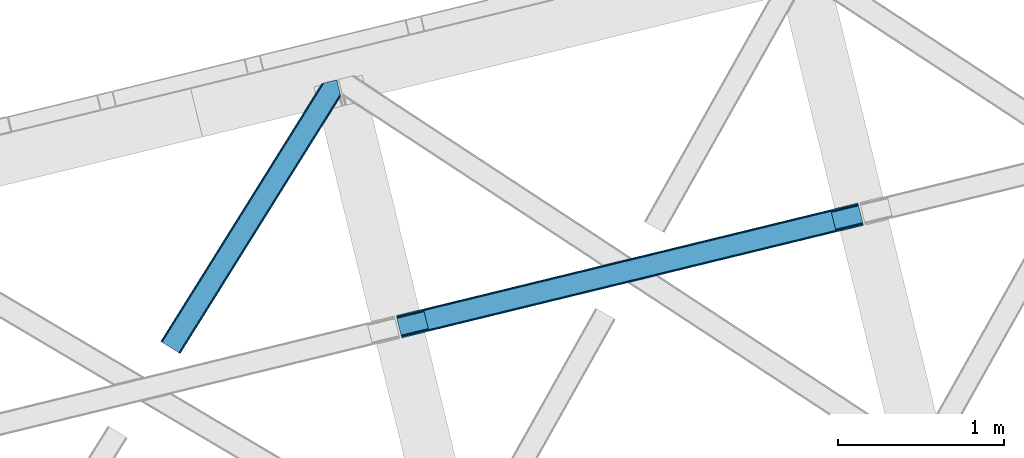
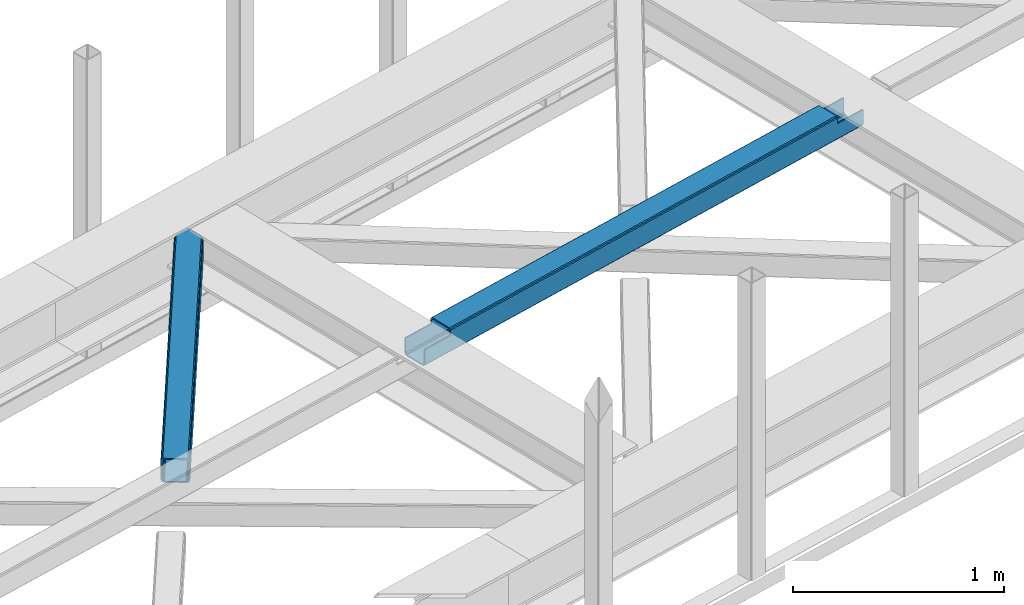
# One storey, part 53 of 66: 1 beam, 1 member.
"""IFC4 building model written with IfcOpenShell, lengths in millimetres."""

from ifc_helpers import new_model, entity, si_unit, converted_unit, derived_unit, direction, frame, origin, place, context, subcontext, project, spatial, triangles, polygons, material, type_object, element, save


model = new_model("IFC4")

# Units and contexts
model_context = context("Model", 3, precision=0.01, world=origin(), true_north=direction((6.12303176911189e-17, 1.0)))
plan_context = context("Plan", 3, precision=0.01, world=origin(), true_north=direction((6.12303176911189e-17, 1.0)))
body_context = subcontext(model_context, "Body", "Model", "MODEL_VIEW")
ifc_project = project(units=[si_unit("LENGTHUNIT", "METRE", prefix="MILLI"), si_unit("AREAUNIT", "SQUARE_METRE"), si_unit("VOLUMEUNIT", "CUBIC_METRE"), converted_unit("PLANEANGLEUNIT", "DEGREE", entity("IfcRatioMeasure", 0.0174532925199433), si_unit("PLANEANGLEUNIT", "RADIAN"), dimensions=[0, 0, 0, 0, 0, 0, 0]), si_unit("MASSUNIT", "GRAM", prefix="KILO"), derived_unit("MASSDENSITYUNIT", [(si_unit("MASSUNIT", "GRAM", prefix="KILO"), 1), (si_unit("LENGTHUNIT", "METRE"), -3)]), derived_unit("MOMENTOFINERTIAUNIT", [(si_unit("LENGTHUNIT", "METRE"), 4)]), si_unit("TIMEUNIT", "SECOND"), si_unit("FREQUENCYUNIT", "HERTZ"), si_unit("THERMODYNAMICTEMPERATUREUNIT", "DEGREE_CELSIUS"), derived_unit("THERMALTRANSMITTANCEUNIT", [(si_unit("MASSUNIT", "GRAM", prefix="KILO"), 1), (si_unit("THERMODYNAMICTEMPERATUREUNIT", "KELVIN"), -1), (si_unit("TIMEUNIT", "SECOND"), -3)]), derived_unit("VOLUMETRICFLOWRATEUNIT", [(si_unit("LENGTHUNIT", "METRE"), 3), (si_unit("TIMEUNIT", "SECOND"), -1)]), derived_unit("MASSFLOWRATEUNIT", [(si_unit("MASSUNIT", "GRAM", prefix="KILO"), 1), (si_unit("TIMEUNIT", "SECOND"), -1)]), derived_unit("ROTATIONALFREQUENCYUNIT", [(si_unit("TIMEUNIT", "SECOND"), -1)]), si_unit("ELECTRICCURRENTUNIT", "AMPERE"), si_unit("ELECTRICVOLTAGEUNIT", "VOLT"), si_unit("POWERUNIT", "WATT"), si_unit("FORCEUNIT", "NEWTON", prefix="KILO"), si_unit("ILLUMINANCEUNIT", "LUX"), si_unit("LUMINOUSFLUXUNIT", "LUMEN"), si_unit("LUMINOUSINTENSITYUNIT", "CANDELA"), derived_unit("USERDEFINED", [(si_unit("MASSUNIT", "GRAM", prefix="KILO"), -1), (si_unit("LENGTHUNIT", "METRE"), -2), (si_unit("TIMEUNIT", "SECOND"), 3), (si_unit("LUMINOUSFLUXUNIT", "LUMEN"), 1)]), derived_unit("LINEARVELOCITYUNIT", [(si_unit("LENGTHUNIT", "METRE"), 1), (si_unit("TIMEUNIT", "SECOND"), -1)]), si_unit("PRESSUREUNIT", "PASCAL"), derived_unit("USERDEFINED", [(si_unit("LENGTHUNIT", "METRE"), -2), (si_unit("MASSUNIT", "GRAM", prefix="KILO"), 1), (si_unit("TIMEUNIT", "SECOND"), -2)]), derived_unit("LINEARFORCEUNIT", [(si_unit("MASSUNIT", "GRAM", prefix="KILO"), 1), (si_unit("LENGTHUNIT", "METRE"), 1), (si_unit("TIMEUNIT", "SECOND"), -2), (si_unit("LENGTHUNIT", "METRE"), -1)]), derived_unit("PLANARFORCEUNIT", [(si_unit("MASSUNIT", "GRAM", prefix="KILO"), 1), (si_unit("LENGTHUNIT", "METRE"), 1), (si_unit("TIMEUNIT", "SECOND"), -2), (si_unit("LENGTHUNIT", "METRE"), -2)])], contexts=[model_context, plan_context])

# Site, building, storey
site_placement = place(None, origin())
site = spatial("IfcSite", under=ifc_project, at=site_placement, CompositionType="ELEMENT")
building_placement = place(site_placement, origin())
building = spatial("IfcBuilding", under=site, at=building_placement, CompositionType="ELEMENT")
storey_placement = place(building_placement, frame((0.0, 0.0, 19800.0)))
storey = spatial("IfcBuildingStorey", under=building, at=storey_placement, Name="06", CompositionType="ELEMENT", Elevation=19800.0)

# Beam
ifc_material = material(Name="Metal painted (White)")
beam_type = type_object("IfcBeamType", PredefinedType="BEAM")
beam_placement = place(storey_placement, frame((-11387.67, 16364.08, 3967.02)))
element("IfcBeam", 1, at=beam_placement, inside=storey, type_object=beam_type, material=ifc_material, ObjectType="Steel Beam", PredefinedType="BEAM", context=body_context, shape_type="Tessellation", body=[
    polygons([(31.1823923917571, 8.09507685196108, 17.8030399336114), (31.4978703677273, 6.80086440699434, 24.4999999999988), (2817.90917311746, 686.018099103278, 24.4999999999988), (2817.59369514149, 687.312311548247, 17.8030399336114), (30.2839871259056, 11.7806820741864, 12.1256313292298), (2816.69528987564, 690.997916770472, 12.1256313292298), (28.9394286278213, 17.2965800886753, 8.33210818105214), (2815.35073137756, 696.513814784959, 8.33210818105214), (27.3534137403861, 23.8030254244661, 7.00000000000274), (2813.76471649012, 703.020260120752, 7.00000000000274), (4.21622439083043, 118.720708051134, 8.33210818105214), (5.80223927826556, 112.214262715343, 7.00000000000274), (2792.213542028, 791.431497411626, 7.00000000000274), (2790.62752714057, 797.937942747419, 8.33210818105214), (2.87166589274824, 124.236606065618, 12.1256313292342), (2789.28296864248, 803.453840761904, 12.1256313292342), (1.9732606268946, 127.922211287848, 17.8030399336114), (2788.38456337663, 807.139445984131, 17.8030399336114), (1.65778265094818, 129.216423732819, 24.4999999999988), (2788.06908540067, 808.433658429104, 24.4999999999988), (33.1556530186734, 6.49720277579036e-12, 17.5000000000004), (33.1556530186734, 6.49720277579036e-12, 99.499999999999), (31.4978703677403, 6.80086440699434, 99.499999999999), (1.65778265095251, 129.216423732821, 99.499999999999), (2.38230768445646e-11, 136.017288139815, 99.499999999999), (2.59888111031614e-11, 136.017288139815, 17.5000000000004), (0.315477975985408, 134.723075694844, 10.803039933613), (1.21388324183688, 131.037470472619, 5.12563132923143), (2.55844173992124, 125.52157245813, 1.33210818105373), (4.14445662735637, 119.015127122339, 0.0), (29.011196391343, 17.0021610174826, 0.0), (30.5972112787781, 10.4957156816896, 1.33210818105373), (31.9417697768603, 4.97981766720068, 5.12563132923576), (32.8401750427139, 1.29421244497757, 10.803039933613), (2786.41130274975, 815.234522836097, 17.5000000000004), (2786.41130274974, 815.234522836097, 99.499999999999), (2788.06908540068, 808.433658429104, 99.499999999999), (2817.90917311746, 686.01809910328, 99.499999999999), (2819.56695576839, 679.217234696288, 99.499999999999), (2819.5669557684, 679.217234696288, 17.5000000000004), (2819.25147779244, 680.511447141259, 10.803039933613), (2818.35307252658, 684.197052363484, 5.12563132923576), (2817.0085140285, 689.712950377973, 1.33210818105373), (2815.42249914106, 696.219395713764, 0.0), (2790.55575937708, 798.23236181862, 0.0), (2788.96974448964, 804.738807154413, 1.33210818105373), (2787.62518599156, 810.254705168902, 5.12563132923143), (2786.72678072571, 813.940310391125, 10.803039933613), (2653.72536552979, 645.996559503588, 115.5000123926), (2653.78173361466, 646.010298722204, 100.117303289864), (2654.68842734968, 646.231315480896, 99.499999999999), (194.718606580794, 46.5876811586757, 99.5063429816656), (195.631369831915, 46.810141494503, 100.117301735448), (195.690168193622, 46.824474122359, 115.5), (2656.34621000061, 639.430451073908, 99.499999999999), (2655.43964990836, 639.209466900397, 100.117303484932), (2655.38006714068, 639.194943868054, 122.500007895425), (197.345360928049, 40.0229783796023, 122.500002534479), (197.338587096739, 40.0213271441479, 100.500009163303), (196.748205195722, 39.8773799905087, 99.5697919021647), (2624.84834918759, 768.646841677419, 99.5063429816656), (2623.93924032811, 768.4252715147, 100.117299778624), (2623.88287224324, 768.411532296082, 115.50000888136), (165.850080476841, 169.240033448183, 115.5), (165.84046220334, 169.237688832046, 100.50000941238), (165.250325295035, 169.093836777333, 99.5761204674868), (2622.81875057266, 775.357142845586, 99.5697919021647), (163.220745767765, 175.804071762184, 99.499999999999), (164.133244938514, 176.026503182399, 100.117301984524), (164.18943998763, 176.04020120897, 122.500002796667), (2622.22174126673, 775.211580304167, 122.500003994045), (2622.23184455557, 775.214043718734, 100.500018741102), (2622.53385542111, 773.916547681999, 129.196959150505), (2623.4271909467, 770.229706340309, 134.874360354937), (2624.76848195077, 764.7130116355, 138.667878733795), (2626.35352903677, 758.206330327425, 139.999985502214), (2651.2242780837, 656.194341778115, 139.999991354279), (2652.81177220129, 649.688257112712, 138.667885332354), (2654.16003176172, 644.173261502483, 134.874367586349), (2655.06379646893, 640.488963035532, 129.196966804773), (2653.41217589809, 647.2913298996, 122.196975799125), (2652.50841119088, 650.975628366557, 127.874376580702), (2651.16015163044, 656.490623976784, 131.667894326702), (2649.57265751286, 662.996708642187, 133.000000348631), (2628.01800833885, 751.407098718257, 132.999995276841), (2626.43296125285, 757.913780026333, 131.667888508414), (2625.09167024878, 763.43047473114, 127.874370129564), (2624.19833472319, 767.117316072832, 122.196968925133), (164.878528418698, 169.003207355194, 99.499999999999), (193.131726453727, 57.3201898040399, 131.667891818946), (191.545711566292, 63.8266351398329, 133.0), (194.476284951809, 51.804291789551, 127.874368670764), (195.374690217663, 48.1186865673279, 122.196960066391), (169.994537104169, 152.237872430707, 133.0), (166.165558452801, 167.945821003215, 122.196960066391), (167.063963718652, 164.260215780991, 127.874368670764), (168.408522216736, 158.744317766502, 131.667891818946), (197.031411944073, 41.3175635421181, 129.196961104604), (196.136488323068, 45.0040174739024, 134.874366301861), (194.794244157317, 50.5204796458773, 138.667887185257), (193.209023953586, 57.0271186992037, 139.999994588639), (168.341882306943, 159.039986838394, 139.999994981919), (166.755021471191, 165.546225960038, 138.667887628704), (165.408105180735, 171.061549222932, 134.874366787843), (164.506189230969, 174.746298656828, 129.196961619)], [[[1, 2, 3, 4]], [[5, 1, 4, 6]], [[7, 5, 6, 8]], [[9, 7, 8, 10]], [[11, 12, 13, 14]], [[15, 11, 14, 16]], [[17, 15, 16, 18]], [[19, 17, 18, 20]], [[12, 9, 10, 13]], [[21, 22, 23, 2, 1, 5, 7, 9, 12, 11, 15, 17, 19, 24, 25, 26, 27, 28, 29, 30, 31, 32, 33, 34]], [[35, 36, 37, 20, 18, 16, 14, 13, 10, 8, 6, 4, 3, 38, 39, 40, 41, 42, 43, 44, 45, 46, 47, 48]], [[49, 50, 51, 38, 3, 2, 23, 52, 53, 54]], [[55, 39, 38, 51]], [[39, 55, 56, 57, 58, 59, 60, 22, 21, 40]], [[32, 31, 44, 43]], [[33, 32, 43, 42]], [[34, 33, 42, 41]], [[21, 34, 41, 40]], [[31, 30, 45, 44]], [[27, 26, 35, 48]], [[28, 27, 48, 47]], [[29, 28, 47, 46]], [[30, 29, 46, 45]], [[20, 37, 61, 62, 63, 64, 65, 66, 24, 19]], [[67, 36, 35, 26, 25, 68, 69, 70, 71, 72]], [[36, 67, 61, 37]], [[72, 71, 73, 74, 75, 76, 77, 78, 79, 80, 57, 56, 50, 49, 81, 82, 83, 84, 85, 86, 87, 88, 63, 62]], [[60, 52, 23, 22]], [[25, 24, 89, 68]], [[90, 91, 84, 83]], [[92, 90, 83, 82]], [[93, 92, 82, 81]], [[54, 93, 81, 49]], [[94, 85, 84, 91]], [[95, 64, 63, 88]], [[96, 95, 88, 87]], [[97, 96, 87, 86]], [[94, 97, 86, 85]], [[65, 64, 95, 96, 97, 94, 91, 90, 92, 93, 54, 53, 59, 58, 98, 99, 100, 101, 102, 103, 104, 105, 70, 69]], [[98, 58, 57, 80]], [[99, 98, 80, 79]], [[100, 99, 79, 78]], [[101, 100, 78, 77]], [[77, 76, 102, 101]], [[103, 102, 76, 75]], [[104, 103, 75, 74]], [[105, 104, 74, 73]], [[70, 105, 73, 71]]], closed=False),
])

# Member
member_type = type_object("IfcMemberType", PredefinedType="BRACE")
member_placement = place(storey_placement, frame((-12809.64, 16269.34, 3823.0)))
element("IfcMember", 2, at=member_placement, inside=storey, type_object=member_type, ObjectType="Steel Horizontal Brace", PredefinedType="BRACE", context=body_context, shape_type="Tessellation", body=[
    triangles([(933.019793701173, 1535.69114685059, 0.0), (967.779299926759, 1393.09054870606, 0.0), (14.8479309082031, 64.8692962646492, 0.0), (103.918075561523, 9.26687622070313, 0.0), (928.802609252929, 1552.99009094238, 5.49966430664063), (928.943298339844, 1552.41570739746, 5.208984375), (930.802487182616, 1544.78594055176, 1.33247680664135), (971.996484375, 1375.79160461426, 5.49966430664063), (971.856958007813, 1376.36598815918, 5.208984375), (969.996606445313, 1383.99575500488, 1.33247680664135), (972.211587524414, 1375.53696899414, 5.8531311035149), (972.422039794921, 1375.28233337402, 6.20659790039281), (928.915393066407, 1553.56912536621, 5.74383544921875), (972.724346923827, 1375.53696899414, 6.35310058593677), (929.030502319336, 1554.17606506348, 5.9996337890625), (973.025491333008, 1375.79160461426, 6.49960327148438), (929.145611572265, 1554.78300476074, 6.25543212890625), (929.253744506836, 1555.36087646485, 6.49960327148438), (4.3520599365238, 71.4223846435543, 5.12526855468968), (1.13365173339844, 73.4315643310547, 10.8039916992202), (973.359191894531, 1630.84231567383, 10.8039916992202), (976.915951538085, 1631.70854187012, 6.49960327148438), (9.16804504394531, 68.4155914306648, 1.33247680664135), (971.506979370117, 1630.3900177002, 17.5012573242202), (0.0, 74.1361724853523, 17.5012573242202), (1081.10028991699, 1548.91592102051, 6.49960327148438), (1056.20762329101, 1651.03643188476, 6.49960327148438), (971.506979370117, 1630.3900177002, 122.499499511719), (0.0, 74.1361724853523, 122.499499511719), (973.359191894531, 1630.84231567383, 129.196765136719), (1.13365173339844, 73.4315643310547, 129.196765136719), (978.636776733398, 1632.12828369141, 134.87548828125), (4.3520599365238, 71.4223846435543, 134.87548828125), (986.530480957032, 1634.05258483887, 138.668280029298), (9.16804504394531, 68.4155914306648, 138.668280029298), (995.83921508789, 1636.32105102539, 140.00075683594), (14.8479309082031, 64.8692962646492, 140.00075683594), (118.762518310547, 0.0, 17.5012573242202), (117.632354736328, 0.705770874023074, 10.8039916992202), (1085.14190368652, 1551.24949951172, 10.9783996582046), (1087.41618347168, 1552.56337280274, 13.4991760253906), (109.597961425781, 5.7205810546875, 1.33247680664135), (114.413946533203, 2.71378784179615, 5.12526855468968), (1087.56966247559, 1551.93434143066, 17.5012573242202), (1081.77583007812, 1575.70149536133, 140.00075683594), (1063.00837097168, 1652.69447021484, 140.00075683594), (103.918075561523, 9.26687622070313, 140.00075683594), (1083.99313659668, 1566.60553894043, 138.668280029298), (109.597961425781, 5.7205810546875, 138.668280029298), (1085.8720916748, 1558.8955444336, 134.87548828125), (114.413946533203, 2.71378784179615, 134.87548828125), (1087.12782897949, 1553.7435333252, 129.196765136719), (117.632354736328, 0.705770874023074, 129.196765136719), (1087.56966247559, 1551.93434143066, 122.499499511719), (118.762518310547, 0.0, 122.499499511719), (1082.53973693848, 1566.77297058106, 12.1248413085959), (1083.96406860352, 1566.72297363281, 13.4991760253906), (1077.85048828125, 1569.98440246582, 8.3320495605476), (1074.64952087402, 1577.50022277832, 6.99957275390625), (1056.69596557617, 1651.1561920166, 6.99957275390625), (1005.57234191895, 1638.6941619873, 6.99957275390625), (20.7836151123047, 61.1613830566403, 6.99957275390625), (97.9789031982418, 12.9736267089847, 6.99957275390625), (108.474774169921, 6.42053833007776, 12.1248413085959), (111.693182373047, 4.4113586425774, 17.8035644531265), (1084.81052856445, 1563.24992980957, 17.8035644531265), (103.6587890625, 9.42733154296911, 8.3320495605476), (1085.25236206055, 1561.44073791504, 24.5008300781265), (112.822183227539, 3.70675048828161, 24.5008300781265), (983.092318725587, 1633.21426391602, 17.8035644531265), (981.240106201172, 1632.76312866211, 24.5008300781265), (7.06817321777271, 69.7236511230476, 17.8035644531265), (5.93917236328161, 70.4294219970707, 24.5008300781265), (988.369903564453, 1634.50139465332, 12.1248413085959), (10.2865814208981, 67.7144714355472, 12.1248413085959), (996.263607788085, 1636.42569580078, 8.3320495605476), (15.1025665283196, 64.7088409423832, 8.3320495605476), (981.240106201172, 1632.76312866211, 115.499926757813), (5.93917236328161, 70.4294219970707, 115.499926757813), (996.263607788085, 1636.42569580078, 131.668707275392), (1005.57234191895, 1638.6941619873, 133.001184082033), (1063.00837097168, 1652.69447021484, 133.001184082033), (988.369903564453, 1634.50139465332, 127.873590087893), (983.092318725587, 1633.21426391602, 122.197192382813), (20.7836151123047, 61.1613830566403, 133.001184082033), (15.1025665283196, 64.7088409423832, 131.668707275392), (10.2865814208981, 67.7144714355472, 127.873590087893), (7.06817321777271, 69.7236511230476, 122.197192382813), (108.474774169921, 6.42053833007776, 127.873590087893), (111.693182373047, 4.4113586425774, 122.197192382813), (112.822183227539, 3.70675048828161, 115.499926757813), (97.9789031982418, 12.9736267089847, 133.001184082033), (103.6587890625, 9.42733154296911, 131.668707275392), (1085.25236206055, 1561.44073791504, 115.499926757813), (1084.81052856445, 1563.24992980957, 122.197192382813), (1083.55479125976, 1568.40194091797, 127.873590087893), (1081.67583618164, 1576.11309814453, 131.668707275392), (1079.45852966309, 1585.2078918457, 133.001184082033)], [[1, 2, 3], [4, 3, 2], [1, 5, 2], [6, 5, 1], [1, 7, 6], [2, 5, 8], [8, 9, 2], [10, 2, 9], [11, 8, 5], [12, 11, 13], [14, 12, 15], [16, 14, 17], [17, 18, 16], [15, 17, 14], [13, 15, 12], [5, 13, 11], [17, 19, 18], [19, 17, 15], [13, 19, 15], [19, 13, 5], [5, 6, 19], [20, 21, 18], [18, 19, 20], [21, 22, 18], [19, 6, 7], [7, 1, 23], [3, 23, 1], [7, 23, 19], [24, 21, 20], [20, 25, 24], [18, 26, 16], [26, 18, 22], [27, 26, 22], [28, 24, 25], [25, 29, 28], [30, 28, 31], [29, 31, 28], [32, 30, 33], [31, 33, 30], [34, 32, 35], [33, 35, 32], [36, 34, 37], [35, 37, 34], [38, 39, 40], [40, 41, 38], [42, 10, 9], [39, 12, 16], [16, 40, 39], [16, 26, 40], [9, 39, 43], [9, 12, 39], [9, 43, 42], [2, 10, 4], [42, 4, 10], [41, 44, 38], [45, 36, 37], [36, 45, 46], [37, 47, 45], [48, 45, 47], [47, 49, 48], [50, 48, 49], [49, 51, 50], [52, 50, 51], [51, 53, 52], [54, 52, 53], [53, 55, 54], [44, 54, 55], [55, 38, 44], [56, 40, 26], [41, 40, 56], [56, 57, 41], [58, 26, 59], [26, 58, 56], [60, 59, 26], [59, 61, 62], [61, 59, 60], [62, 63, 59], [64, 65, 66], [66, 57, 64], [58, 59, 63], [63, 67, 58], [56, 58, 67], [67, 64, 56], [57, 56, 64], [68, 66, 65], [65, 69, 68], [70, 71, 72], [73, 72, 71], [74, 70, 75], [72, 75, 70], [76, 74, 77], [75, 77, 74], [61, 76, 62], [77, 62, 76], [71, 78, 73], [79, 73, 78], [34, 36, 80], [46, 81, 36], [81, 46, 82], [81, 80, 36], [83, 34, 80], [83, 32, 34], [32, 84, 30], [84, 32, 83], [28, 84, 78], [84, 28, 30], [61, 22, 76], [70, 74, 22], [74, 76, 22], [61, 60, 22], [71, 70, 24], [21, 24, 70], [28, 71, 24], [71, 28, 78], [70, 22, 21], [80, 81, 85], [85, 86, 80], [83, 80, 86], [86, 87, 83], [84, 83, 87], [87, 88, 84], [78, 84, 88], [88, 79, 78], [53, 89, 90], [91, 38, 55], [53, 90, 55], [53, 51, 89], [90, 91, 55], [89, 51, 49], [92, 47, 37], [47, 93, 49], [93, 47, 92], [93, 89, 49], [39, 64, 43], [69, 38, 91], [38, 65, 39], [65, 38, 69], [39, 65, 64], [4, 63, 3], [42, 43, 64], [64, 67, 42], [67, 63, 4], [4, 42, 67], [87, 35, 33], [37, 85, 92], [37, 86, 85], [86, 37, 35], [87, 86, 35], [79, 29, 25], [31, 88, 87], [33, 31, 87], [88, 31, 29], [79, 88, 29], [23, 75, 19], [3, 63, 62], [62, 77, 3], [77, 75, 23], [23, 3, 77], [20, 19, 75], [25, 73, 79], [72, 25, 20], [25, 72, 73], [72, 20, 75], [66, 41, 57], [54, 44, 68], [44, 66, 68], [68, 94, 54], [44, 41, 66], [95, 54, 94], [52, 54, 95], [50, 95, 96], [95, 50, 52], [96, 48, 50], [97, 48, 96], [97, 98, 45], [97, 45, 48], [98, 46, 45], [98, 82, 46], [81, 98, 85], [81, 82, 98], [92, 85, 98], [95, 94, 90], [91, 90, 94], [96, 95, 89], [90, 89, 95], [97, 96, 93], [89, 93, 96], [98, 97, 92], [93, 92, 97], [94, 68, 91], [69, 91, 68]]),
])

save(model, "model.ifc")
